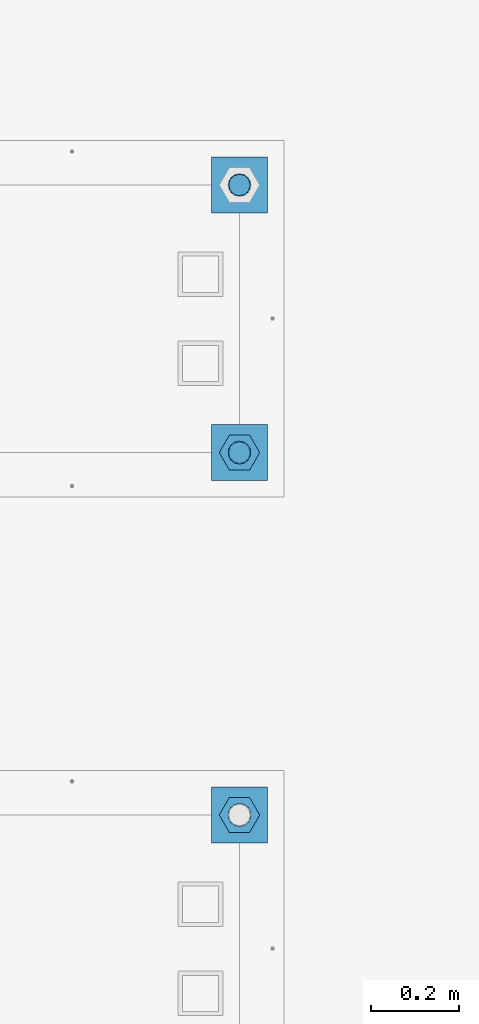
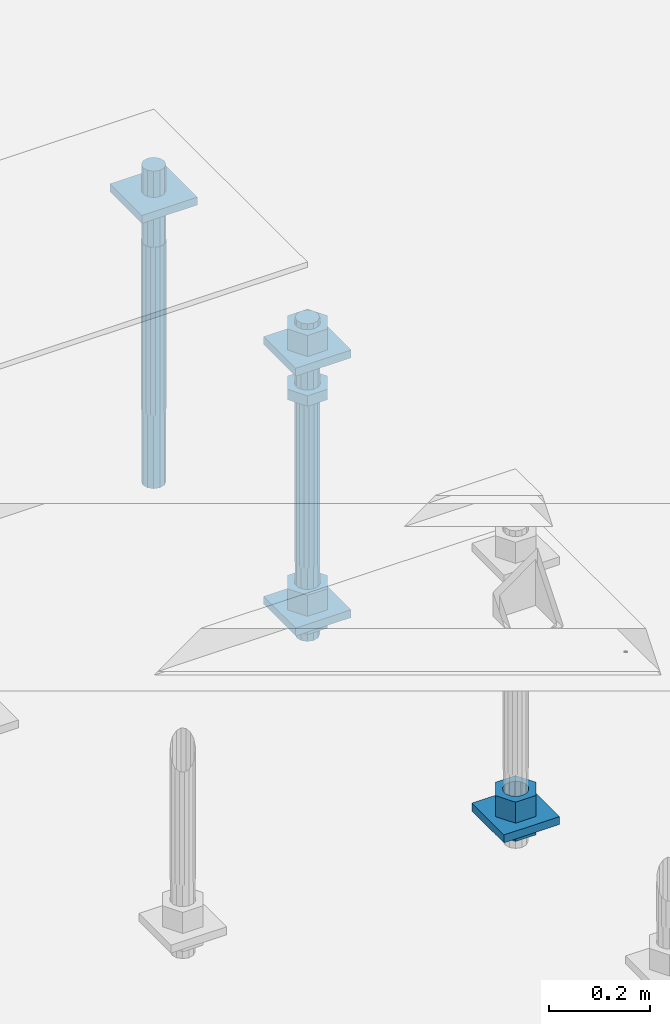
# One storey, part 2565 of 3843: 12 beams, 2 elements without a shape of their own.
"""IFC2X3 building model written with IfcOpenShell, lengths in millimetres."""

import ifcopenshell
import ifcopenshell.guid

model = None  # the IFC model being written
_history = None  # IfcOwnerHistory: only IFC2X3 demands one
_inside = {}  # id of a spatial element -> (the spatial element, [elements in it])
_under = {}  # id of a project, library or spatial element -> (it, [spatial elements below it])
_declared = {}  # id of a project -> (the project, [libraries it declares])
_typed = {}  # id of a type object -> (the type object, [elements of that type])
_made_of = {}  # id of a material, layer set ... -> (it, [elements and type objects made of it])


def new_model(schema):
    """Start an empty IFC model of exactly this schema.

    Asked for "IFC4X3", IfcOpenShell would pick the latest addendum, in which some entities
    have other attributes; the version numbers below select the first issue.
    IFC2X3 requires an IfcOwnerHistory on every rooted entity: one is made here for all.
    """
    global model, _history
    if schema == "IFC4X3":
        model = ifcopenshell.file(schema_version=(4, 3, 0, 0))
    else:
        model = ifcopenshell.file(schema=schema)
    _inside.clear()
    _under.clear()
    _declared.clear()
    _typed.clear()
    _made_of.clear()
    _history = None
    if model.schema == "IFC2X3":
        org = make("IfcOrganization", Name="unknown")
        user = make(
            "IfcPersonAndOrganization",
            ThePerson=make("IfcPerson", FamilyName="unknown"),
            TheOrganization=org,
        )
        app = make(
            "IfcApplication",
            ApplicationDeveloper=org,
            Version="unknown",
            ApplicationFullName="unknown",
            ApplicationIdentifier="unknown",
        )
        _history = make(
            "IfcOwnerHistory",
            OwningUser=user,
            OwningApplication=app,
            ChangeAction="ADDED",
            CreationDate=0,
        )
    return model


def make(cls, **values):
    """One entity of the class cls with the attributes given. An attribute that is None is left unset."""
    return model.create_entity(
        cls, **{name: value for name, value in values.items() if value is not None}
    )


def rooted(cls, **values):
    """An entity with a GlobalId (a new one), such as an element, a storey or a relation."""
    return make(cls, GlobalId=ifcopenshell.guid.new(), OwnerHistory=_history, **values)


def si_unit(unit_type, name, prefix=None):
    """IfcSIUnit, for example si_unit("LENGTHUNIT", "METRE", prefix="MILLI")."""
    return make("IfcSIUnit", UnitType=unit_type, Prefix=prefix, Name=name)


def assignment(units):
    """IfcUnitAssignment: the units of a project."""
    return None if units is None else make("IfcUnitAssignment", Units=units)


def point(xyz):
    """IfcCartesianPoint."""
    return None if xyz is None else make("IfcCartesianPoint", Coordinates=xyz)


def direction(xyz):
    """IfcDirection."""
    return None if xyz is None else make("IfcDirection", DirectionRatios=xyz)


def frame(location, z_axis=None, x_axis=None):
    """IfcAxis2Placement3D, a coordinate frame: its origin and axes. An axis left out is left unset."""
    return make(
        "IfcAxis2Placement3D",
        Location=point(location),
        Axis=direction(z_axis),
        RefDirection=direction(x_axis),
    )


def origin_with_axes():
    """The frame at (0, 0, 0) with the z axis (0, 0, 1) and the x axis (1, 0, 0) written out."""
    return frame((0.0, 0.0, 0.0), z_axis=(0.0, 0.0, 1.0), x_axis=(1.0, 0.0, 0.0))


def place(relative_to, where):
    """IfcLocalPlacement: puts the frame where relative to a parent placement (None: the world)."""
    return make(
        "IfcLocalPlacement", PlacementRelTo=relative_to, RelativePlacement=where
    )


def context(
    kind, dimensions, precision=None, world=None, true_north=None, identifier=None
):
    """IfcGeometricRepresentationContext, for example the 3D "Model" context."""
    return make(
        "IfcGeometricRepresentationContext",
        ContextIdentifier=identifier,
        ContextType=kind,
        CoordinateSpaceDimension=dimensions,
        Precision=precision,
        WorldCoordinateSystem=world,
        TrueNorth=true_north,
    )


def subcontext(parent, identifier, kind, view, scale=None):
    """IfcGeometricRepresentationSubContext, for example "Body" below "Model"."""
    return make(
        "IfcGeometricRepresentationSubContext",
        ContextIdentifier=identifier,
        ContextType=kind,
        ParentContext=parent,
        TargetScale=scale,
        TargetView=view,
    )


def project(units=None, contexts=None):
    """IfcProject with its units and contexts."""
    return rooted(
        "IfcProject",
        Name="project",
        RepresentationContexts=contexts,
        UnitsInContext=assignment(units),
    )


def spatial(cls, under=None, at=None, **own):
    """A site, building, storey or space (cls), placed at a placement, below another one or the project."""
    s = rooted(cls, ObjectPlacement=at, **own)
    if under is not None:
        _under.setdefault(under.id(), (under, []))[1].append(s)
    return s


def faces_of(points, faces, orient=None, outer=None):
    """IfcFace entities. A face is a list of loops; a loop is a list of indices into points, from 0.

    orient and outer hold one flag for each loop. By default every Orientation is true, the
    first loop of a face is its IfcFaceOuterBound and the others are IfcFaceBound.
    """
    made = []
    for i, loops in enumerate(faces):
        bounds = []
        for j, loop in enumerate(loops):
            is_outer = j == 0 if outer is None else outer[i][j]
            bounds.append(
                make(
                    "IfcFaceOuterBound" if is_outer else "IfcFaceBound",
                    Bound=make("IfcPolyLoop", Polygon=[points[k] for k in loop]),
                    Orientation=True if orient is None else orient[i][j],
                )
            )
        made.append(make("IfcFace", Bounds=bounds))
    return made


def faceted_brep(points, faces, orient=None, outer=None, voids=None):
    """IfcFacetedBrep: a solid bounded by flat faces; with voids (closed shells), ...WithVoids."""
    shared = [point(p) for p in points]
    hull = make("IfcClosedShell", CfsFaces=faces_of(shared, faces, orient, outer))
    if voids is None:
        return make("IfcFacetedBrep", Outer=hull)
    return make(
        "IfcFacetedBrepWithVoids",
        Outer=hull,
        Voids=[
            make(cls, CfsFaces=faces_of(shared, fs, o, b)) for cls, fs, o, b in voids
        ],
    )


def shape(context_of_items, identifier, shape_type, items):
    """IfcShapeRepresentation: the items that make up one representation, for example the "Body"."""
    return make(
        "IfcShapeRepresentation",
        ContextOfItems=context_of_items,
        RepresentationIdentifier=identifier,
        RepresentationType=shape_type,
        Items=items,
    )


def material(Name=None, Category=None):
    """IfcMaterial."""
    return make("IfcMaterial", Name=Name, Category=Category)


def made_of(thing, what):
    """Note that an element or type object is made of a material, layer set ...; save() writes the relation."""
    if what is not None:
        _made_of.setdefault(what.id(), (what, []))[1].append(thing)
    return thing


def type_object(cls, material=None, **own):
    """A type object (cls), such as IfcWallType, which elements share."""
    return made_of(rooted(cls, **own), material)


def element(
    cls,
    number,
    at=None,
    inside=None,
    cuts=None,
    type_object=None,
    material=None,
    context=None,
    identifier="Body",
    shape_type=None,
    held_by="IfcProductDefinitionShape",
    body=None,
    shapes=None,
    **own,
):
    """One element of the class cls, such as IfcWall. Its Tag is "e" and its number.

    at: its placement. inside: the storey or other place that contains it. cuts: it is an
    opening in that element (IfcRelVoidsElement). A single representation is given by context,
    identifier, shape_type and body (its items); several are given by shapes. held_by: the class
    of the entity that holds the representations. save() writes the other relations.
    """
    e = rooted(cls, Tag="e%d" % number, ObjectPlacement=at, **own)
    if body is not None:
        shapes = [shape(context, identifier, shape_type, body)]
    if shapes is not None:
        e.Representation = make(held_by, Representations=shapes)
    if inside is not None:
        _inside.setdefault(inside.id(), (inside, []))[1].append(e)
    if cuts is not None:
        rooted(
            "IfcRelVoidsElement", RelatingBuildingElement=cuts, RelatedOpeningElement=e
        )
    if type_object is not None:
        _typed.setdefault(type_object.id(), (type_object, []))[1].append(e)
    return made_of(e, material)


def aggregate(whole, parts):
    """IfcRelAggregates: a whole, such as a stair, and the parts it consists of."""
    return rooted("IfcRelAggregates", RelatingObject=whole, RelatedObjects=parts)


def save(model, path):
    """Write the relations noted so far, then the file.

    IfcRelAggregates (storeys below a building ...), IfcRelContainedInSpatialStructure (elements
    in a storey), IfcRelDefinesByType, IfcRelAssociatesMaterial and IfcRelDeclares: one each for
    every whole, place, type object, material and project.
    """
    for whole, parts in _under.values():
        aggregate(whole, parts)
    for where, things in _inside.values():
        rooted(
            "IfcRelContainedInSpatialStructure",
            RelatedElements=things,
            RelatingStructure=where,
        )
    for kind, things in _typed.values():
        rooted("IfcRelDefinesByType", RelatedObjects=things, RelatingType=kind)
    for what, things in _made_of.values():
        rooted("IfcRelAssociatesMaterial", RelatedObjects=things, RelatingMaterial=what)
    for by, libraries in _declared.values():
        rooted("IfcRelDeclares", RelatingContext=by, RelatedDefinitions=libraries)
    model.write(path)


model = new_model("IFC2X3")

# Units and contexts
model_context = context("Model", 3, precision=1e-05, world=origin_with_axes())
body_context = subcontext(model_context, "Body", "Model", "MODEL_VIEW")
ifc_project = project(units=[si_unit("LENGTHUNIT", "METRE", prefix="MILLI"), si_unit("AREAUNIT", "SQUARE_METRE"), si_unit("VOLUMEUNIT", "CUBIC_METRE"), si_unit("MASSUNIT", "GRAM", prefix="KILO"), si_unit("TIMEUNIT", "SECOND"), si_unit("PLANEANGLEUNIT", "RADIAN"), si_unit("SOLIDANGLEUNIT", "STERADIAN"), si_unit("THERMODYNAMICTEMPERATUREUNIT", "DEGREE_CELSIUS"), si_unit("LUMINOUSINTENSITYUNIT", "LUMEN")], contexts=[model_context])

# Site, building, storey
site_placement = place(None, origin_with_axes())
site = spatial("IfcSite", under=ifc_project, at=site_placement, CompositionType="ELEMENT")
building_placement = place(site_placement, origin_with_axes())
building = spatial("IfcBuilding", under=site, at=building_placement, Name="Undefined", CompositionType="ELEMENT")
storey_placement = place(building_placement, origin_with_axes())
storey = spatial("IfcBuildingStorey", under=building, at=storey_placement, Name="Undefined", CompositionType="ELEMENT", Elevation=0.0)

# Assembly, beam
assembly_1_placement = place(storey_placement, origin_with_axes())
assembly_1 = element("IfcElementAssembly", 1, at=assembly_1_placement, inside=storey, Name="TEMPLATE", AssemblyPlace="NOTDEFINED", PredefinedType="RIGID_FRAME")
ifc_material_1 = material(Name="STEEL/A572-50")
beam_type_1 = type_object("IfcBeamType", PredefinedType="NOTDEFINED")
beam_1_placement = place(assembly_1_placement, frame((105537.0, 1892.30000152587, 29244.925), z_axis=(1.0, 0.0, 0.0), x_axis=(0.0, 1.0, 0.0)))
beam_1 = element("IfcBeam", 2, at=beam_1_placement, type_object=beam_type_1, material=ifc_material_1, Name="WASHER_PLATE", context=body_context, shape_type="Brep", body=[
    faceted_brep([(0.0, 9.52500000000146, -63.5), (0.0, 9.52500000000146, 63.5), (127.0, 9.52500000000146, 63.5), (127.0, 9.52500000000146, -63.5), (0.0, -9.52500000000146, 63.5), (127.0, -9.52500000000146, 63.5), (0.0, -9.52500000000146, -63.5), (127.0, -9.52500000000146, -63.5)], [[[0, 1, 2, 3]], [[1, 4, 5, 2]], [[4, 6, 7, 5]], [[6, 0, 3, 7]], [[5, 7, 3, 2]], [[6, 4, 1, 0]]]),
])

# Assembly, beams
assembly_2_placement = place(storey_placement, origin_with_axes())
assembly_2 = element("IfcElementAssembly", 3, at=assembly_2_placement, inside=storey, Name="TEMPLATE", AssemblyPlace="NOTDEFINED", PredefinedType="RIGID_FRAME")
beam_2_placement = place(assembly_2_placement, frame((105537.0, 2717.80000152587, 29873.575), z_axis=(1.0, 0.0, 0.0), x_axis=(0.0, 1.0, 0.0)))
beam_2 = element("IfcBeam", 4, at=beam_2_placement, type_object=beam_type_1, material=ifc_material_1, Name="WASHER_PLATE", context=body_context, shape_type="Brep", body=[
    faceted_brep([(0.0, 9.52500000000146, -63.5), (0.0, 9.52500000000146, 63.5), (127.0, 9.52500000000146, 63.5), (127.0, 9.52500000000146, -63.5), (0.0, -9.52500000000146, 63.5), (127.0, -9.52500000000146, 63.5), (0.0, -9.52500000000146, -63.5), (127.0, -9.52500000000146, -63.5)], [[[0, 1, 2, 3]], [[1, 4, 5, 2]], [[4, 6, 7, 5]], [[6, 0, 3, 7]], [[5, 7, 3, 2]], [[6, 4, 1, 0]]]),
])
beam_3_placement = place(assembly_2_placement, frame((105537.0, 3327.40000152587, 29873.575), z_axis=(1.0, 0.0, 0.0), x_axis=(0.0, 1.0, 0.0)))
beam_3 = element("IfcBeam", 5, at=beam_3_placement, type_object=beam_type_1, material=ifc_material_1, Name="WASHER_PLATE", context=body_context, shape_type="Brep", body=[
    faceted_brep([(0.0, 9.52500000000146, -63.5), (0.0, 9.52500000000146, 63.5), (127.0, 9.52500000000146, 63.5), (127.0, 9.52500000000146, -63.5), (0.0, -9.52500000000146, 63.5), (127.0, -9.52500000000146, 63.5), (0.0, -9.52500000000146, -63.5), (127.0, -9.52500000000146, -63.5)], [[[0, 1, 2, 3]], [[1, 4, 5, 2]], [[4, 6, 7, 5]], [[6, 0, 3, 7]], [[5, 7, 3, 2]], [[6, 4, 1, 0]]]),
])
beam_4_placement = place(assembly_2_placement, frame((105537.0, 2717.80000152587, 29244.925), z_axis=(1.0, 0.0, 0.0), x_axis=(0.0, 1.0, 0.0)))
beam_4 = element("IfcBeam", 6, at=beam_4_placement, type_object=beam_type_1, material=ifc_material_1, Name="WASHER_PLATE", context=body_context, shape_type="Brep", body=[
    faceted_brep([(0.0, 9.52500000000146, -63.5), (0.0, 9.52500000000146, 63.5), (127.0, 9.52500000000146, 63.5), (127.0, 9.52500000000146, -63.5), (0.0, -9.52500000000146, 63.5), (127.0, -9.52500000000146, 63.5), (0.0, -9.52500000000146, -63.5), (127.0, -9.52500000000146, -63.5)], [[[0, 1, 2, 3]], [[1, 4, 5, 2]], [[4, 6, 7, 5]], [[6, 0, 3, 7]], [[5, 7, 3, 2]], [[6, 4, 1, 0]]]),
])

# Beam
ifc_material_2 = material(Name="STEEL/A36")
beam_type_2 = type_object("IfcBeamType", Name="2_HALF_NUT", PredefinedType="NOTDEFINED")
beam_5_placement = place(assembly_1_placement, frame((105537.0, 1955.80000152587, 29235.4), z_axis=(0.0, 1.0, 0.0), x_axis=(0.0, 0.0, -1.0)))
beam_5 = element("IfcBeam", 7, at=beam_5_placement, type_object=beam_type_2, material=ifc_material_2, Name="NUT", ObjectType="2_HALF_NUT", context=body_context, shape_type="Brep", body=[
    faceted_brep([(0.0, -46.0369987487793, 0.0), (0.0, -23.0184993743896, -39.869213104248), (25.4000000000015, -23.0184993743896, -39.869213104248), (25.4000000000015, -46.0369987487793, 0.0), (0.0, 23.0184993743896, -39.869213104248), (25.4000000000015, 23.0184993743896, -39.869213104248), (0.0, 46.0369987487793, 0.0), (25.4000000000015, 46.0369987487793, 0.0), (0.0, 23.0184993743896, 39.869213104248), (25.4000000000015, 23.0184993743896, 39.869213104248), (0.0, -23.0184993743896, 39.869213104248), (25.4000000000015, -23.0184993743896, 39.869213104248), (0.0, 0.0, 26.1940002441406), (0.0, 11.3650617044477, 23.5999013092805), (25.4000000000015, 11.3650617044477, 23.5999013092805), (25.4000000000015, 0.0, 26.1940002441406), (0.0, 20.4791109456419, 16.3316083006721), (25.4000000000015, 20.4791109456419, 16.3316083006721), (0.0, 25.5370200498292, 5.82867859874386), (25.4000000000015, 25.5370200498292, 5.82867859874386), (0.0, 25.5370200498292, -5.82867859874386), (25.4000000000015, 25.5370200498292, -5.82867859874386), (0.0, 20.4791109456419, -16.3316083006721), (25.4000000000015, 20.4791109456419, -16.3316083006721), (0.0, 11.3650617044477, -23.5999013092805), (25.4000000000015, 11.3650617044477, -23.5999013092805), (0.0, 0.0, -26.1940002441406), (25.4000000000015, 0.0, -26.1940002441406), (0.0, -11.3650617044477, -23.5999013092805), (25.4000000000015, -11.3650617044477, -23.5999013092805), (0.0, -20.4791109456419, -16.3316083006721), (25.4000000000015, -20.4791109456419, -16.3316083006721), (0.0, -25.5370200498292, -5.82867859874386), (25.4000000000015, -25.5370200498292, -5.82867859874386), (0.0, -25.5370200498292, 5.82867859874386), (25.4000000000015, -25.5370200498292, 5.82867859874386), (0.0, -20.4791109456419, 16.3316083006721), (25.4000000000015, -20.4791109456419, 16.3316083006721), (0.0, -11.3650617044477, 23.5999013092805), (25.4000000000015, -11.3650617044477, 23.5999013092805)], [[[0, 1, 2, 3]], [[1, 4, 5, 2]], [[4, 6, 7, 5]], [[6, 8, 9, 7]], [[8, 10, 11, 9]], [[10, 0, 3, 11]], [[12, 13, 14, 15]], [[13, 16, 17, 14]], [[16, 18, 19, 17]], [[18, 20, 21, 19]], [[20, 22, 23, 21]], [[22, 24, 25, 23]], [[24, 26, 27, 25]], [[26, 28, 29, 27]], [[28, 30, 31, 29]], [[30, 32, 33, 31]], [[32, 34, 35, 33]], [[34, 36, 37, 35]], [[36, 38, 39, 37]], [[38, 12, 15, 39]], [[5, 7, 9, 11, 3, 2], [17, 19, 21, 23, 25, 27, 29, 31, 33, 35, 37, 39, 15, 14]], [[10, 8, 6, 4, 1, 0], [38, 36, 34, 32, 30, 28, 26, 24, 22, 20, 18, 16, 13, 12]]]),
])

beam_6_placement = place(assembly_2_placement, frame((105537.0, 2781.30000152587, 29787.85), z_axis=(0.0, 1.0, 0.0), x_axis=(0.0, 0.0, -1.0)))
beam_6 = element("IfcBeam", 8, at=beam_6_placement, type_object=beam_type_2, material=ifc_material_2, Name="NUT", ObjectType="2_HALF_NUT", context=body_context, shape_type="Brep", body=[
    faceted_brep([(0.0, -46.0369987487793, 0.0), (0.0, -23.0184993743896, -39.869213104248), (25.4000000000015, -23.0184993743896, -39.869213104248), (25.4000000000015, -46.0369987487793, 0.0), (0.0, 23.0184993743896, -39.869213104248), (25.4000000000015, 23.0184993743896, -39.869213104248), (0.0, 46.0369987487793, 0.0), (25.4000000000015, 46.0369987487793, 0.0), (0.0, 23.0184993743896, 39.869213104248), (25.4000000000015, 23.0184993743896, 39.869213104248), (0.0, -23.0184993743896, 39.869213104248), (25.4000000000015, -23.0184993743896, 39.869213104248), (0.0, 0.0, 26.1940002441406), (0.0, 11.3650617044477, 23.5999013092805), (25.4000000000015, 11.3650617044477, 23.5999013092805), (25.4000000000015, 0.0, 26.1940002441406), (0.0, 20.4791109456419, 16.3316083006721), (25.4000000000015, 20.4791109456419, 16.3316083006721), (0.0, 25.5370200498292, 5.82867859874386), (25.4000000000015, 25.5370200498292, 5.82867859874386), (0.0, 25.5370200498292, -5.82867859874386), (25.4000000000015, 25.5370200498292, -5.82867859874386), (0.0, 20.4791109456419, -16.3316083006721), (25.4000000000015, 20.4791109456419, -16.3316083006721), (0.0, 11.3650617044477, -23.5999013092805), (25.4000000000015, 11.3650617044477, -23.5999013092805), (0.0, 0.0, -26.1940002441406), (25.4000000000015, 0.0, -26.1940002441406), (0.0, -11.3650617044477, -23.5999013092805), (25.4000000000015, -11.3650617044477, -23.5999013092805), (0.0, -20.4791109456419, -16.3316083006721), (25.4000000000015, -20.4791109456419, -16.3316083006721), (0.0, -25.5370200498292, -5.82867859874386), (25.4000000000015, -25.5370200498292, -5.82867859874386), (0.0, -25.5370200498292, 5.82867859874386), (25.4000000000015, -25.5370200498292, 5.82867859874386), (0.0, -20.4791109456419, 16.3316083006721), (25.4000000000015, -20.4791109456419, 16.3316083006721), (0.0, -11.3650617044477, 23.5999013092805), (25.4000000000015, -11.3650617044477, 23.5999013092805)], [[[0, 1, 2, 3]], [[1, 4, 5, 2]], [[4, 6, 7, 5]], [[6, 8, 9, 7]], [[8, 10, 11, 9]], [[10, 0, 3, 11]], [[12, 13, 14, 15]], [[13, 16, 17, 14]], [[16, 18, 19, 17]], [[18, 20, 21, 19]], [[20, 22, 23, 21]], [[22, 24, 25, 23]], [[24, 26, 27, 25]], [[26, 28, 29, 27]], [[28, 30, 31, 29]], [[30, 32, 33, 31]], [[32, 34, 35, 33]], [[34, 36, 37, 35]], [[36, 38, 39, 37]], [[38, 12, 15, 39]], [[5, 7, 9, 11, 3, 2], [17, 19, 21, 23, 25, 27, 29, 31, 33, 35, 37, 39, 15, 14]], [[10, 8, 6, 4, 1, 0], [38, 36, 34, 32, 30, 28, 26, 24, 22, 20, 18, 16, 13, 12]]]),
])

beam_7_placement = place(assembly_2_placement, frame((105537.0, 2781.30000152587, 29235.4), z_axis=(0.0, 1.0, 0.0), x_axis=(0.0, 0.0, -1.0)))
beam_7 = element("IfcBeam", 9, at=beam_7_placement, type_object=beam_type_2, material=ifc_material_2, Name="NUT", ObjectType="2_HALF_NUT", context=body_context, shape_type="Brep", body=[
    faceted_brep([(0.0, -46.0369987487793, 0.0), (0.0, -23.0184993743896, -39.869213104248), (25.4000000000015, -23.0184993743896, -39.869213104248), (25.4000000000015, -46.0369987487793, 0.0), (0.0, 23.0184993743896, -39.869213104248), (25.4000000000015, 23.0184993743896, -39.869213104248), (0.0, 46.0369987487793, 0.0), (25.4000000000015, 46.0369987487793, 0.0), (0.0, 23.0184993743896, 39.869213104248), (25.4000000000015, 23.0184993743896, 39.869213104248), (0.0, -23.0184993743896, 39.869213104248), (25.4000000000015, -23.0184993743896, 39.869213104248), (0.0, 0.0, 26.1940002441406), (0.0, 11.3650617044477, 23.5999013092805), (25.4000000000015, 11.3650617044477, 23.5999013092805), (25.4000000000015, 0.0, 26.1940002441406), (0.0, 20.4791109456419, 16.3316083006721), (25.4000000000015, 20.4791109456419, 16.3316083006721), (0.0, 25.5370200498292, 5.82867859874386), (25.4000000000015, 25.5370200498292, 5.82867859874386), (0.0, 25.5370200498292, -5.82867859874386), (25.4000000000015, 25.5370200498292, -5.82867859874386), (0.0, 20.4791109456419, -16.3316083006721), (25.4000000000015, 20.4791109456419, -16.3316083006721), (0.0, 11.3650617044477, -23.5999013092805), (25.4000000000015, 11.3650617044477, -23.5999013092805), (0.0, 0.0, -26.1940002441406), (25.4000000000015, 0.0, -26.1940002441406), (0.0, -11.3650617044477, -23.5999013092805), (25.4000000000015, -11.3650617044477, -23.5999013092805), (0.0, -20.4791109456419, -16.3316083006721), (25.4000000000015, -20.4791109456419, -16.3316083006721), (0.0, -25.5370200498292, -5.82867859874386), (25.4000000000015, -25.5370200498292, -5.82867859874386), (0.0, -25.5370200498292, 5.82867859874386), (25.4000000000015, -25.5370200498292, 5.82867859874386), (0.0, -20.4791109456419, 16.3316083006721), (25.4000000000015, -20.4791109456419, 16.3316083006721), (0.0, -11.3650617044477, 23.5999013092805), (25.4000000000015, -11.3650617044477, 23.5999013092805)], [[[0, 1, 2, 3]], [[1, 4, 5, 2]], [[4, 6, 7, 5]], [[6, 8, 9, 7]], [[8, 10, 11, 9]], [[10, 0, 3, 11]], [[12, 13, 14, 15]], [[13, 16, 17, 14]], [[16, 18, 19, 17]], [[18, 20, 21, 19]], [[20, 22, 23, 21]], [[22, 24, 25, 23]], [[24, 26, 27, 25]], [[26, 28, 29, 27]], [[28, 30, 31, 29]], [[30, 32, 33, 31]], [[32, 34, 35, 33]], [[34, 36, 37, 35]], [[36, 38, 39, 37]], [[38, 12, 15, 39]], [[5, 7, 9, 11, 3, 2], [17, 19, 21, 23, 25, 27, 29, 31, 33, 35, 37, 39, 15, 14]], [[10, 8, 6, 4, 1, 0], [38, 36, 34, 32, 30, 28, 26, 24, 22, 20, 18, 16, 13, 12]]]),
])

beam_type_3 = type_object("IfcBeamType", Name="2_HEAVY_HEX_NUT", PredefinedType="NOTDEFINED")
beam_8_placement = place(assembly_1_placement, frame((105537.0, 1955.80000152587, 29305.25), z_axis=(0.0, 1.0, 0.0), x_axis=(0.0, 0.0, -1.0)))
beam_8 = element("IfcBeam", 10, at=beam_8_placement, type_object=beam_type_3, material=ifc_material_2, Name="NUT", ObjectType="2_HEAVY_HEX_NUT", context=body_context, shape_type="Brep", body=[
    faceted_brep([(0.0, -46.0369987487793, 0.0), (0.0, -23.0184993743896, -39.869213104248), (50.7999999999993, -23.0184993743896, -39.869213104248), (50.7999999999993, -46.0369987487793, 0.0), (0.0, 23.0184993743896, -39.869213104248), (50.7999999999993, 23.0184993743896, -39.869213104248), (0.0, 46.0369987487793, 0.0), (50.7999999999993, 46.0369987487793, 0.0), (0.0, 23.0184993743896, 39.869213104248), (50.7999999999993, 23.0184993743896, 39.869213104248), (0.0, -23.0184993743896, 39.869213104248), (50.7999999999993, -23.0184993743896, 39.869213104248), (0.0, 0.0, 26.1940002441406), (0.0, 11.3650617044477, 23.5999013092805), (50.7999999999993, 11.3650617044477, 23.5999013092805), (50.7999999999993, 0.0, 26.1940002441406), (0.0, 20.4791109456419, 16.3316083006721), (50.7999999999993, 20.4791109456419, 16.3316083006721), (0.0, 25.5370200498292, 5.82867859874386), (50.7999999999993, 25.5370200498292, 5.82867859874386), (0.0, 25.5370200498292, -5.82867859874386), (50.7999999999993, 25.5370200498292, -5.82867859874386), (0.0, 20.4791109456419, -16.3316083006721), (50.7999999999993, 20.4791109456419, -16.3316083006721), (0.0, 11.3650617044477, -23.5999013092805), (50.7999999999993, 11.3650617044477, -23.5999013092805), (0.0, 0.0, -26.1940002441406), (50.7999999999993, 0.0, -26.1940002441406), (0.0, -11.3650617044477, -23.5999013092805), (50.7999999999993, -11.3650617044477, -23.5999013092805), (0.0, -20.4791109456419, -16.3316083006721), (50.7999999999993, -20.4791109456419, -16.3316083006721), (0.0, -25.5370200498292, -5.82867859874386), (50.7999999999993, -25.5370200498292, -5.82867859874386), (0.0, -25.5370200498292, 5.82867859874386), (50.7999999999993, -25.5370200498292, 5.82867859874386), (0.0, -20.4791109456419, 16.3316083006721), (50.7999999999993, -20.4791109456419, 16.3316083006721), (0.0, -11.3650617044477, 23.5999013092805), (50.7999999999993, -11.3650617044477, 23.5999013092805)], [[[0, 1, 2, 3]], [[1, 4, 5, 2]], [[4, 6, 7, 5]], [[6, 8, 9, 7]], [[8, 10, 11, 9]], [[10, 0, 3, 11]], [[12, 13, 14, 15]], [[13, 16, 17, 14]], [[16, 18, 19, 17]], [[18, 20, 21, 19]], [[20, 22, 23, 21]], [[22, 24, 25, 23]], [[24, 26, 27, 25]], [[26, 28, 29, 27]], [[28, 30, 31, 29]], [[30, 32, 33, 31]], [[32, 34, 35, 33]], [[34, 36, 37, 35]], [[36, 38, 39, 37]], [[38, 12, 15, 39]], [[5, 7, 9, 11, 3, 2], [17, 19, 21, 23, 25, 27, 29, 31, 33, 35, 37, 39, 15, 14]], [[10, 8, 6, 4, 1, 0], [38, 36, 34, 32, 30, 28, 26, 24, 22, 20, 18, 16, 13, 12]]]),
])

aggregate(assembly_1, [beam_8, beam_5, beam_1])

beam_9_placement = place(assembly_2_placement, frame((105537.0, 2781.30000152587, 29933.9), z_axis=(0.0, 1.0, 0.0), x_axis=(0.0, 0.0, -1.0)))
beam_9 = element("IfcBeam", 11, at=beam_9_placement, type_object=beam_type_3, material=ifc_material_2, Name="NUT", ObjectType="2_HEAVY_HEX_NUT", context=body_context, shape_type="Brep", body=[
    faceted_brep([(0.0, -46.0369987487793, 0.0), (0.0, -23.0184993743896, -39.869213104248), (50.7999999999993, -23.0184993743896, -39.869213104248), (50.7999999999993, -46.0369987487793, 0.0), (0.0, 23.0184993743896, -39.869213104248), (50.7999999999993, 23.0184993743896, -39.869213104248), (0.0, 46.0369987487793, 0.0), (50.7999999999993, 46.0369987487793, 0.0), (0.0, 23.0184993743896, 39.869213104248), (50.7999999999993, 23.0184993743896, 39.869213104248), (0.0, -23.0184993743896, 39.869213104248), (50.7999999999993, -23.0184993743896, 39.869213104248), (0.0, 0.0, 26.1940002441406), (0.0, 11.3650617044477, 23.5999013092805), (50.7999999999993, 11.3650617044477, 23.5999013092805), (50.7999999999993, 0.0, 26.1940002441406), (0.0, 20.4791109456419, 16.3316083006721), (50.7999999999993, 20.4791109456419, 16.3316083006721), (0.0, 25.5370200498292, 5.82867859874386), (50.7999999999993, 25.5370200498292, 5.82867859874386), (0.0, 25.5370200498292, -5.82867859874386), (50.7999999999993, 25.5370200498292, -5.82867859874386), (0.0, 20.4791109456419, -16.3316083006721), (50.7999999999993, 20.4791109456419, -16.3316083006721), (0.0, 11.3650617044477, -23.5999013092805), (50.7999999999993, 11.3650617044477, -23.5999013092805), (0.0, 0.0, -26.1940002441406), (50.7999999999993, 0.0, -26.1940002441406), (0.0, -11.3650617044477, -23.5999013092805), (50.7999999999993, -11.3650617044477, -23.5999013092805), (0.0, -20.4791109456419, -16.3316083006721), (50.7999999999993, -20.4791109456419, -16.3316083006721), (0.0, -25.5370200498292, -5.82867859874386), (50.7999999999993, -25.5370200498292, -5.82867859874386), (0.0, -25.5370200498292, 5.82867859874386), (50.7999999999993, -25.5370200498292, 5.82867859874386), (0.0, -20.4791109456419, 16.3316083006721), (50.7999999999993, -20.4791109456419, 16.3316083006721), (0.0, -11.3650617044477, 23.5999013092805), (50.7999999999993, -11.3650617044477, 23.5999013092805)], [[[0, 1, 2, 3]], [[1, 4, 5, 2]], [[4, 6, 7, 5]], [[6, 8, 9, 7]], [[8, 10, 11, 9]], [[10, 0, 3, 11]], [[12, 13, 14, 15]], [[13, 16, 17, 14]], [[16, 18, 19, 17]], [[18, 20, 21, 19]], [[20, 22, 23, 21]], [[22, 24, 25, 23]], [[24, 26, 27, 25]], [[26, 28, 29, 27]], [[28, 30, 31, 29]], [[30, 32, 33, 31]], [[32, 34, 35, 33]], [[34, 36, 37, 35]], [[36, 38, 39, 37]], [[38, 12, 15, 39]], [[5, 7, 9, 11, 3, 2], [17, 19, 21, 23, 25, 27, 29, 31, 33, 35, 37, 39, 15, 14]], [[10, 8, 6, 4, 1, 0], [38, 36, 34, 32, 30, 28, 26, 24, 22, 20, 18, 16, 13, 12]]]),
])

beam_10_placement = place(assembly_2_placement, frame((105537.0, 2781.30000152587, 29305.25), z_axis=(0.0, 1.0, 0.0), x_axis=(0.0, 0.0, -1.0)))
beam_10 = element("IfcBeam", 12, at=beam_10_placement, type_object=beam_type_3, material=ifc_material_2, Name="NUT", ObjectType="2_HEAVY_HEX_NUT", context=body_context, shape_type="Brep", body=[
    faceted_brep([(0.0, -46.0369987487793, 0.0), (0.0, -23.0184993743896, -39.869213104248), (50.7999999999993, -23.0184993743896, -39.869213104248), (50.7999999999993, -46.0369987487793, 0.0), (0.0, 23.0184993743896, -39.869213104248), (50.7999999999993, 23.0184993743896, -39.869213104248), (0.0, 46.0369987487793, 0.0), (50.7999999999993, 46.0369987487793, 0.0), (0.0, 23.0184993743896, 39.869213104248), (50.7999999999993, 23.0184993743896, 39.869213104248), (0.0, -23.0184993743896, 39.869213104248), (50.7999999999993, -23.0184993743896, 39.869213104248), (0.0, 0.0, 26.1940002441406), (0.0, 11.3650617044477, 23.5999013092805), (50.7999999999993, 11.3650617044477, 23.5999013092805), (50.7999999999993, 0.0, 26.1940002441406), (0.0, 20.4791109456419, 16.3316083006721), (50.7999999999993, 20.4791109456419, 16.3316083006721), (0.0, 25.5370200498292, 5.82867859874386), (50.7999999999993, 25.5370200498292, 5.82867859874386), (0.0, 25.5370200498292, -5.82867859874386), (50.7999999999993, 25.5370200498292, -5.82867859874386), (0.0, 20.4791109456419, -16.3316083006721), (50.7999999999993, 20.4791109456419, -16.3316083006721), (0.0, 11.3650617044477, -23.5999013092805), (50.7999999999993, 11.3650617044477, -23.5999013092805), (0.0, 0.0, -26.1940002441406), (50.7999999999993, 0.0, -26.1940002441406), (0.0, -11.3650617044477, -23.5999013092805), (50.7999999999993, -11.3650617044477, -23.5999013092805), (0.0, -20.4791109456419, -16.3316083006721), (50.7999999999993, -20.4791109456419, -16.3316083006721), (0.0, -25.5370200498292, -5.82867859874386), (50.7999999999993, -25.5370200498292, -5.82867859874386), (0.0, -25.5370200498292, 5.82867859874386), (50.7999999999993, -25.5370200498292, 5.82867859874386), (0.0, -20.4791109456419, 16.3316083006721), (50.7999999999993, -20.4791109456419, 16.3316083006721), (0.0, -11.3650617044477, 23.5999013092805), (50.7999999999993, -11.3650617044477, 23.5999013092805)], [[[0, 1, 2, 3]], [[1, 4, 5, 2]], [[4, 6, 7, 5]], [[6, 8, 9, 7]], [[8, 10, 11, 9]], [[10, 0, 3, 11]], [[12, 13, 14, 15]], [[13, 16, 17, 14]], [[16, 18, 19, 17]], [[18, 20, 21, 19]], [[20, 22, 23, 21]], [[22, 24, 25, 23]], [[24, 26, 27, 25]], [[26, 28, 29, 27]], [[28, 30, 31, 29]], [[30, 32, 33, 31]], [[32, 34, 35, 33]], [[34, 36, 37, 35]], [[36, 38, 39, 37]], [[38, 12, 15, 39]], [[5, 7, 9, 11, 3, 2], [17, 19, 21, 23, 25, 27, 29, 31, 33, 35, 37, 39, 15, 14]], [[10, 8, 6, 4, 1, 0], [38, 36, 34, 32, 30, 28, 26, 24, 22, 20, 18, 16, 13, 12]]]),
])

ifc_material_3 = material()
beam_type_4 = type_object("IfcBeamType", PredefinedType="NOTDEFINED")
beam_11_placement = place(assembly_2_placement, frame((105537.000001526, 3390.89999999999, 29762.45), z_axis=(1.0, 0.0, 0.0), x_axis=(0.0, 0.0, -1.0)))
beam_11 = element("IfcBeam", 13, at=beam_11_placement, type_object=beam_type_4, material=ifc_material_3, Name="ANCHOR_ROD", context=body_context, shape_type="Brep", body=[
    faceted_brep([(0.0, -23.4665401257807, -9.72015918207035), (0.0, -17.9605122421344, -17.9605122421417), (406.399999999998, -17.9605122421344, -17.9605122421417), (406.399999999998, -23.4665401257807, -9.72015918207035), (0.0, -9.72015918207762, -23.466540125788), (406.399999999998, -9.72015918207762, -23.466540125788), (0.0, 0.0, -25.4000000000015), (406.399999999998, 0.0, -25.4000000000015), (0.0, 9.72015918207762, -23.466540125788), (406.399999999998, 9.72015918207762, -23.466540125788), (0.0, 17.9605122421344, -17.9605122421417), (406.399999999998, 17.9605122421344, -17.9605122421417), (0.0, 23.4665401257807, -9.72015918207035), (406.399999999998, 23.4665401257807, -9.72015918207035), (0.0, 25.3999996185303, 0.0), (406.399999999998, 25.3999999999942, 0.0), (0.0, 23.4665401257807, 9.72015918207035), (406.399999999998, 23.4665401257807, 9.72015918207035), (0.0, 17.9605122421344, 17.9605122421417), (406.399999999998, 17.9605122421344, 17.9605122421417), (0.0, 9.72015918207762, 23.466540125788), (406.399999999998, 9.72015918207762, 23.466540125788), (0.0, 0.0, 25.4000000000015), (406.399999999998, 0.0, 25.4000000000015), (0.0, -9.72015918207762, 23.466540125788), (406.399999999998, -9.72015918207762, 23.466540125788), (0.0, -17.9605122421344, 17.9605122421417), (406.399999999998, -17.9605122421344, 17.9605122421417), (0.0, -23.4665401257807, 9.72015918207035), (406.399999999998, -23.4665401257807, 9.72015918207035), (0.0, -25.3999996185303, 0.0), (406.399999999998, -25.3999999999942, 0.0), (584.200000000001, -12.2499999999854, -21.2176223927163), (584.200000000001, 1.45519152283669e-11, -24.5), (584.200000000001, 12.2500000000146, -21.2176223927163), (584.200000000001, 21.2176223927381, -12.25), (584.200000000001, 24.5000000000146, 0.0), (584.200000000001, 21.2176223927381, 12.25), (584.200000000001, 12.2500000000146, 21.2176223927163), (584.200000000001, 1.45519152283669e-11, 24.5), (584.200000000001, -12.2499999999854, 21.2176223927163), (584.200000000001, -21.217622392709, 12.25), (584.200000000001, -24.4999999999854, 0.0), (584.200000000001, -21.217622392709, -12.25), (406.399999999998, -24.4999999999854, 0.0), (406.399999999998, -21.217622392709, -12.25), (406.399999999998, -12.2499999999854, -21.2176223927163), (406.399999999998, 1.45519152283669e-11, -24.5), (406.399999999998, 12.2500000000146, -21.2176223927163), (406.399999999998, 21.2176223927381, -12.25), (406.399999999998, 24.5000000000146, 0.0), (406.399999999998, 21.2176223927381, 12.25), (406.399999999998, 12.2500000000146, 21.2176223927163), (406.399999999998, 1.45519152283669e-11, 24.5), (406.399999999998, -12.2499999999854, 21.2176223927163), (406.399999999998, -21.217622392709, 12.25), (0.0, 12.2500000000146, 21.2176223927163), (0.0, 1.45519152283669e-11, 24.5), (0.0, -12.2499999999854, 21.2176223927163), (0.0, -21.217622392709, 12.25), (0.0, -24.4999999999854, 0.0), (0.0, -21.217622392709, -12.25), (0.0, -12.2499999999854, -21.2176223927163), (0.0, 1.45519152283669e-11, -24.5), (0.0, 12.2500000000146, -21.2176223927163), (0.0, 21.2176223927381, -12.25), (0.0, 24.5000000000146, 0.0), (0.0, 21.2176223927381, 12.25), (-184.150000000001, -21.217622392709, 12.25), (-184.150000000001, -12.2499999999854, 21.2176223927163), (-184.150000000001, 1.45519152283669e-11, 24.5), (-184.150000000001, 12.2500000000146, 21.2176223927163), (-184.150000000001, 21.2176223927381, 12.25), (-184.150000000001, 24.5000000000146, 0.0), (-184.150000000001, 21.2176223927381, -12.25), (-184.150000000001, 12.2500000000146, -21.2176223927163), (-184.150000000001, 1.45519152283669e-11, -24.5), (-184.150000000001, -12.2499999999854, -21.2176223927163), (-184.150000000001, -21.217622392709, -12.25), (-184.150000000001, -24.4999999999854, 0.0)], [[[0, 1, 2, 3]], [[1, 4, 5, 2]], [[4, 6, 7, 5]], [[6, 8, 9, 7]], [[8, 10, 11, 9]], [[10, 12, 13, 11]], [[12, 14, 15, 13]], [[14, 16, 17, 15]], [[16, 18, 19, 17]], [[18, 20, 21, 19]], [[20, 22, 23, 21]], [[22, 24, 25, 23]], [[24, 26, 27, 25]], [[26, 28, 29, 27]], [[28, 30, 31, 29]], [[32, 33, 34, 35, 36, 37, 38, 39, 40, 41, 42, 43]], [[43, 42, 44, 45]], [[32, 43, 45, 46]], [[33, 32, 46, 47]], [[34, 33, 47, 48]], [[35, 34, 48, 49]], [[36, 35, 49, 50]], [[37, 36, 50, 51]], [[38, 37, 51, 52]], [[39, 38, 52, 53]], [[40, 39, 53, 54]], [[41, 40, 54, 55]], [[42, 41, 55, 44]], [[2, 5, 7, 9, 11, 13, 15, 17, 19, 21, 23, 25, 27, 29, 31, 3], [54, 53, 52, 51, 50, 49, 48, 47, 46, 45, 44, 55]], [[30, 0, 3, 31]], [[28, 26, 24, 22, 20, 18, 16, 14, 12, 10, 8, 6, 4, 1, 0, 30], [56, 57, 58, 59, 60, 61, 62, 63, 64, 65, 66, 67]], [[68, 69, 70, 71, 72, 73, 74, 75, 76, 77, 78, 79]], [[71, 70, 57, 56]], [[72, 71, 56, 67]], [[73, 72, 67, 66]], [[74, 73, 66, 65]], [[75, 74, 65, 64]], [[76, 75, 64, 63]], [[77, 76, 63, 62]], [[78, 77, 62, 61]], [[79, 78, 61, 60]], [[68, 79, 60, 59]], [[69, 68, 59, 58]], [[70, 69, 58, 57]]]),
])

beam_12_placement = place(assembly_2_placement, frame((105537.000001526, 2781.29999999998, 29762.45), z_axis=(1.0, 0.0, 0.0), x_axis=(0.0, 0.0, -1.0)))
beam_12 = element("IfcBeam", 14, at=beam_12_placement, type_object=beam_type_4, material=ifc_material_3, Name="ANCHOR_ROD", context=body_context, shape_type="Brep", body=[
    faceted_brep([(0.0, -23.4665401257807, -9.72015918207035), (0.0, -17.9605122421344, -17.9605122421417), (406.399999999998, -17.9605122421344, -17.9605122421417), (406.399999999998, -23.4665401257807, -9.72015918207035), (0.0, -9.72015918207762, -23.466540125788), (406.399999999998, -9.72015918207762, -23.466540125788), (0.0, 0.0, -25.4000000000015), (406.399999999998, 0.0, -25.4000000000015), (0.0, 9.72015918207762, -23.466540125788), (406.399999999998, 9.72015918207762, -23.466540125788), (0.0, 17.9605122421344, -17.9605122421417), (406.399999999998, 17.9605122421344, -17.9605122421417), (0.0, 23.4665401257807, -9.72015918207035), (406.399999999998, 23.4665401257807, -9.72015918207035), (0.0, 25.3999996185303, 0.0), (406.399999999998, 25.3999999999942, 0.0), (0.0, 23.4665401257807, 9.72015918207035), (406.399999999998, 23.4665401257807, 9.72015918207035), (0.0, 17.9605122421344, 17.9605122421417), (406.399999999998, 17.9605122421344, 17.9605122421417), (0.0, 9.72015918207762, 23.466540125788), (406.399999999998, 9.72015918207762, 23.466540125788), (0.0, 0.0, 25.4000000000015), (406.399999999998, 0.0, 25.4000000000015), (0.0, -9.72015918207762, 23.466540125788), (406.399999999998, -9.72015918207762, 23.466540125788), (0.0, -17.9605122421344, 17.9605122421417), (406.399999999998, -17.9605122421344, 17.9605122421417), (0.0, -23.4665401257807, 9.72015918207035), (406.399999999998, -23.4665401257807, 9.72015918207035), (0.0, -25.3999996185303, 0.0), (406.399999999998, -25.3999999999942, 0.0), (584.200000000001, -12.2499999999854, -21.2176223927163), (584.200000000001, 1.45519152283669e-11, -24.5), (584.200000000001, 12.2500000000146, -21.2176223927163), (584.200000000001, 21.2176223927381, -12.25), (584.200000000001, 24.5000000000146, 0.0), (584.200000000001, 21.2176223927381, 12.25), (584.200000000001, 12.2500000000146, 21.2176223927163), (584.200000000001, 1.45519152283669e-11, 24.5), (584.200000000001, -12.2499999999854, 21.2176223927163), (584.200000000001, -21.217622392709, 12.25), (584.200000000001, -24.4999999999854, 0.0), (584.200000000001, -21.217622392709, -12.25), (406.399999999998, -24.4999999999854, 0.0), (406.399999999998, -21.217622392709, -12.25), (406.399999999998, -12.2499999999854, -21.2176223927163), (406.399999999998, 1.45519152283669e-11, -24.5), (406.399999999998, 12.2500000000146, -21.2176223927163), (406.399999999998, 21.2176223927381, -12.25), (406.399999999998, 24.5000000000146, 0.0), (406.399999999998, 21.2176223927381, 12.25), (406.399999999998, 12.2500000000146, 21.2176223927163), (406.399999999998, 1.45519152283669e-11, 24.5), (406.399999999998, -12.2499999999854, 21.2176223927163), (406.399999999998, -21.217622392709, 12.25), (0.0, 12.2500000000146, 21.2176223927163), (0.0, 1.45519152283669e-11, 24.5), (0.0, -12.2499999999854, 21.2176223927163), (0.0, -21.217622392709, 12.25), (0.0, -24.4999999999854, 0.0), (0.0, -21.217622392709, -12.25), (0.0, -12.2499999999854, -21.2176223927163), (0.0, 1.45519152283669e-11, -24.5), (0.0, 12.2500000000146, -21.2176223927163), (0.0, 21.2176223927381, -12.25), (0.0, 24.5000000000146, 0.0), (0.0, 21.2176223927381, 12.25), (-184.150000000001, -21.217622392709, 12.25), (-184.150000000001, -12.2499999999854, 21.2176223927163), (-184.150000000001, 1.45519152283669e-11, 24.5), (-184.150000000001, 12.2500000000146, 21.2176223927163), (-184.150000000001, 21.2176223927381, 12.25), (-184.150000000001, 24.5000000000146, 0.0), (-184.150000000001, 21.2176223927381, -12.25), (-184.150000000001, 12.2500000000146, -21.2176223927163), (-184.150000000001, 1.45519152283669e-11, -24.5), (-184.150000000001, -12.2499999999854, -21.2176223927163), (-184.150000000001, -21.217622392709, -12.25), (-184.150000000001, -24.4999999999854, 0.0)], [[[0, 1, 2, 3]], [[1, 4, 5, 2]], [[4, 6, 7, 5]], [[6, 8, 9, 7]], [[8, 10, 11, 9]], [[10, 12, 13, 11]], [[12, 14, 15, 13]], [[14, 16, 17, 15]], [[16, 18, 19, 17]], [[18, 20, 21, 19]], [[20, 22, 23, 21]], [[22, 24, 25, 23]], [[24, 26, 27, 25]], [[26, 28, 29, 27]], [[28, 30, 31, 29]], [[32, 33, 34, 35, 36, 37, 38, 39, 40, 41, 42, 43]], [[43, 42, 44, 45]], [[32, 43, 45, 46]], [[33, 32, 46, 47]], [[34, 33, 47, 48]], [[35, 34, 48, 49]], [[36, 35, 49, 50]], [[37, 36, 50, 51]], [[38, 37, 51, 52]], [[39, 38, 52, 53]], [[40, 39, 53, 54]], [[41, 40, 54, 55]], [[42, 41, 55, 44]], [[2, 5, 7, 9, 11, 13, 15, 17, 19, 21, 23, 25, 27, 29, 31, 3], [54, 53, 52, 51, 50, 49, 48, 47, 46, 45, 44, 55]], [[30, 0, 3, 31]], [[28, 26, 24, 22, 20, 18, 16, 14, 12, 10, 8, 6, 4, 1, 0, 30], [56, 57, 58, 59, 60, 61, 62, 63, 64, 65, 66, 67]], [[68, 69, 70, 71, 72, 73, 74, 75, 76, 77, 78, 79]], [[71, 70, 57, 56]], [[72, 71, 56, 67]], [[73, 72, 67, 66]], [[74, 73, 66, 65]], [[75, 74, 65, 64]], [[76, 75, 64, 63]], [[77, 76, 63, 62]], [[78, 77, 62, 61]], [[79, 78, 61, 60]], [[68, 79, 60, 59]], [[69, 68, 59, 58]], [[70, 69, 58, 57]]]),
])

aggregate(assembly_2, [beam_11, beam_12, beam_2, beam_3, beam_6, beam_9, beam_10, beam_7, beam_4])

save(model, "model.ifc")
